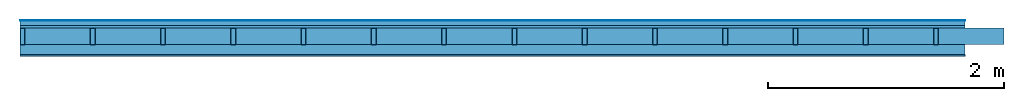
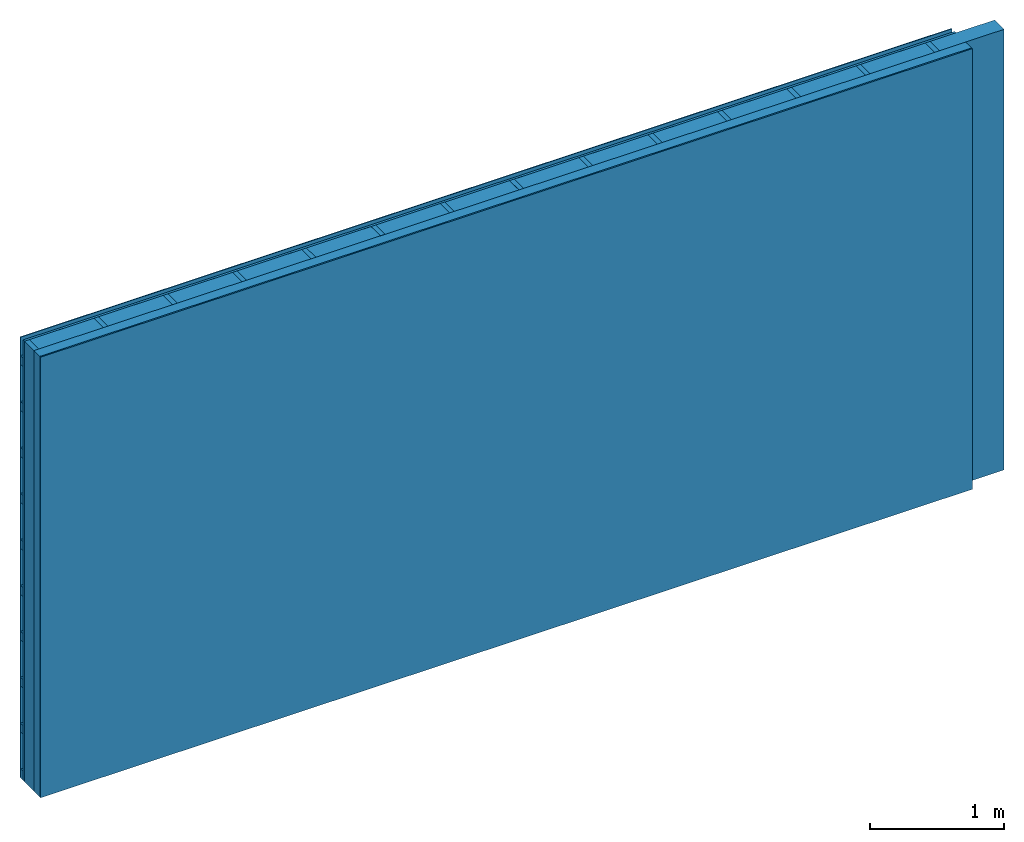
# One storey: 4 plates, 3 members, 1 element without a shape of its own.
"""IFC4 building model written with IfcOpenShell, lengths in metres."""

from ifc_helpers import new_model, si_unit, derived_unit, direction, frame, frame_2d, origin, origin_with_axes, place, context, project, spatial, rectangle, extrude, material, layer, layer_set, type_object, element, aggregate, save


model = new_model("IFC4")

# Units and contexts
plan_context = context("Plan", 3, precision=1e-05, world=origin(), true_north=direction((0.0, 1.0)))
model_context = context("Model", 3, precision=1e-05, world=origin(), true_north=direction((0.0, 1.0)))
ifc_project = project(units=[si_unit("LENGTHUNIT", "METRE"), derived_unit("SOUNDPRESSUREUNIT", [(si_unit("PRESSUREUNIT", "PASCAL", prefix="MICRO"), 0)]), si_unit("ENERGYUNIT", "JOULE", prefix="MEGA"), si_unit("MASSUNIT", "GRAM", prefix="KILO"), derived_unit("THERMALTRANSMITTANCEUNIT", [(si_unit("POWERUNIT", "WATT"), 1), (si_unit("AREAUNIT", "SQUARE_METRE"), -1), (si_unit("THERMODYNAMICTEMPERATUREUNIT", "KELVIN"), -1)]), derived_unit("AREADENSITYUNIT", [(si_unit("MASSUNIT", "GRAM", prefix="KILO"), 1), (si_unit("AREAUNIT", "SQUARE_METRE"), -1)]), derived_unit("USERDEFINED", [(si_unit("ENERGYUNIT", "JOULE", prefix="MEGA"), 1), (si_unit("AREAUNIT", "SQUARE_METRE"), -1)])], contexts=[plan_context, model_context])

# Site, building, storey
site = spatial("IfcSite", under=ifc_project)
building_placement = place(None, origin())
building = spatial("IfcBuilding", under=site, at=building_placement)
storey_placement = place(building_placement, origin())
storey = spatial("IfcBuildingStorey", under=building, at=storey_placement)

# Wall, members, plates
ifc_material_1 = material(Name="mineral, cement-based building board", Category="03.003")
ifc_layer_1 = layer(ifc_material_1, 0.008, Name="Cover 1st layer")
ifc_layer_2 = layer(None, 0.04, Name="Battens / profiles (ventilation)")
ifc_material_2 = material(Category="10.009")
ifc_layer_3 = layer(ifc_material_2, 0.02, Name="outside 1st layer")
ifc_material_3 = material(Name="of the art")
ifc_layer_4 = layer(ifc_material_3, 0.0, Name="Bond")
ifc_layer_5 = layer(None, 0.14, Name="Support")
ifc_layer_6 = layer(ifc_material_3, 0.0, Name="Bond")
ifc_material_4 = material(Name="Solid timber panel")
ifc_layer_7 = layer(ifc_material_4, 0.087, Name="1st layer")
ifc_material_5 = material(Name="Plasterboard type A", Category="03.008")
ifc_layer_8 = layer(ifc_material_5, 0.0125, Name="Covering 1st layer")
ifc_material_6 = material(Name="joints", Category="04.017")
ifc_layer_9 = layer(ifc_material_6, 0.0, Name="Surface")
ifc_layer_set = layer_set([ifc_layer_1, ifc_layer_2, ifc_layer_3, ifc_layer_4, ifc_layer_5, ifc_layer_6, ifc_layer_7, ifc_layer_8, ifc_layer_9])
wall_type = type_object("IfcWallType", Name="D0969", PredefinedType="NOTDEFINED", material=ifc_layer_set)
wall_placement = place(None, frame((0.0, 0.0, 0.0), z_axis=(0.0, -1.0, 0.0), x_axis=(1.0, 0.0, 0.0)))
wall = element("IfcWall", 1, at=wall_placement, inside=storey, type_object=wall_type, material=ifc_layer_set, Name="Wall #1")
ifc_material_7 = material()
member_1_placement = place(wall_placement, origin())
member_1 = element("IfcMember", 2, at=member_1_placement, material=ifc_material_7, Name="Battens / profiles (ventilation)", context=plan_context, shape_type="SweptSolid", body=[
    extrude(rectangle(XDim=0.08, YDim=0.04, at=frame_2d((0.04, 0.02), x_axis=(1.0, 0.0))), frame((0.0, 0.0, 0.008), z_axis=(1.0, 0.0, 0.0), x_axis=(0.0, 1.0, 0.0)), (0.0, 0.0, 1.0), 8.0),
    extrude(rectangle(XDim=0.08, YDim=0.04, at=frame_2d((0.04, 0.02), x_axis=(1.0, 0.0))), frame((0.0, 0.417, 0.008), z_axis=(1.0, 0.0, 0.0), x_axis=(0.0, 1.0, 0.0)), (0.0, 0.0, 1.0), 8.0),
    extrude(rectangle(XDim=0.08, YDim=0.04, at=frame_2d((0.04, 0.02), x_axis=(1.0, 0.0))), frame((0.0, 0.834, 0.008), z_axis=(1.0, 0.0, 0.0), x_axis=(0.0, 1.0, 0.0)), (0.0, 0.0, 1.0), 8.0),
    extrude(rectangle(XDim=0.08, YDim=0.04, at=frame_2d((0.04, 0.02), x_axis=(1.0, 0.0))), frame((0.0, 1.251, 0.008), z_axis=(1.0, 0.0, 0.0), x_axis=(0.0, 1.0, 0.0)), (0.0, 0.0, 1.0), 8.0),
    extrude(rectangle(XDim=0.08, YDim=0.04, at=frame_2d((0.04, 0.02), x_axis=(1.0, 0.0))), frame((0.0, 1.668, 0.008), z_axis=(1.0, 0.0, 0.0), x_axis=(0.0, 1.0, 0.0)), (0.0, 0.0, 1.0), 8.0),
    extrude(rectangle(XDim=0.08, YDim=0.04, at=frame_2d((0.04, 0.02), x_axis=(1.0, 0.0))), frame((0.0, 2.085, 0.008), z_axis=(1.0, 0.0, 0.0), x_axis=(0.0, 1.0, 0.0)), (0.0, 0.0, 1.0), 8.0),
    extrude(rectangle(XDim=0.08, YDim=0.04, at=frame_2d((0.04, 0.02), x_axis=(1.0, 0.0))), frame((0.0, 2.502, 0.008), z_axis=(1.0, 0.0, 0.0), x_axis=(0.0, 1.0, 0.0)), (0.0, 0.0, 1.0), 8.0),
    extrude(rectangle(XDim=0.08, YDim=0.04, at=frame_2d((0.04, 0.02), x_axis=(1.0, 0.0))), frame((0.0, 2.919, 0.008), z_axis=(1.0, 0.0, 0.0), x_axis=(0.0, 1.0, 0.0)), (0.0, 0.0, 1.0), 8.0),
    extrude(rectangle(XDim=0.08, YDim=0.04, at=frame_2d((0.04, 0.02), x_axis=(1.0, 0.0))), frame((0.0, 3.336, 0.008), z_axis=(1.0, 0.0, 0.0), x_axis=(0.0, 1.0, 0.0)), (0.0, 0.0, 1.0), 8.0),
    extrude(rectangle(XDim=0.08, YDim=0.04, at=frame_2d((0.04, 0.02), x_axis=(1.0, 0.0))), frame((0.0, 3.753, 0.008), z_axis=(1.0, 0.0, 0.0), x_axis=(0.0, 1.0, 0.0)), (0.0, 0.0, 1.0), 8.0),
])
ifc_material_8 = material()
member_2_placement = place(wall_placement, origin())
member_2 = element("IfcMember", 3, at=member_2_placement, material=ifc_material_8, Name="Support", context=plan_context, shape_type="SweptSolid", body=[
    extrude(rectangle(XDim=0.04, YDim=0.14, at=frame_2d((0.02, 0.07), x_axis=(1.0, 0.0))), frame((0.0, 4.0, 0.068), z_axis=(0.0, -1.0, 0.0), x_axis=(1.0, 0.0, 0.0)), (0.0, 0.0, 1.0), 4.0),
    extrude(rectangle(XDim=0.04, YDim=0.14, at=frame_2d((0.02, 0.07), x_axis=(1.0, 0.0))), frame((0.595, 4.0, 0.068), z_axis=(0.0, -1.0, 0.0), x_axis=(1.0, 0.0, 0.0)), (0.0, 0.0, 1.0), 4.0),
    extrude(rectangle(XDim=0.04, YDim=0.14, at=frame_2d((0.02, 0.07), x_axis=(1.0, 0.0))), frame((1.19, 4.0, 0.068), z_axis=(0.0, -1.0, 0.0), x_axis=(1.0, 0.0, 0.0)), (0.0, 0.0, 1.0), 4.0),
    extrude(rectangle(XDim=0.04, YDim=0.14, at=frame_2d((0.02, 0.07), x_axis=(1.0, 0.0))), frame((1.785, 4.0, 0.068), z_axis=(0.0, -1.0, 0.0), x_axis=(1.0, 0.0, 0.0)), (0.0, 0.0, 1.0), 4.0),
    extrude(rectangle(XDim=0.04, YDim=0.14, at=frame_2d((0.02, 0.07), x_axis=(1.0, 0.0))), frame((2.38, 4.0, 0.068), z_axis=(0.0, -1.0, 0.0), x_axis=(1.0, 0.0, 0.0)), (0.0, 0.0, 1.0), 4.0),
    extrude(rectangle(XDim=0.04, YDim=0.14, at=frame_2d((0.02, 0.07), x_axis=(1.0, 0.0))), frame((2.975, 4.0, 0.068), z_axis=(0.0, -1.0, 0.0), x_axis=(1.0, 0.0, 0.0)), (0.0, 0.0, 1.0), 4.0),
    extrude(rectangle(XDim=0.04, YDim=0.14, at=frame_2d((0.02, 0.07), x_axis=(1.0, 0.0))), frame((3.57, 4.0, 0.068), z_axis=(0.0, -1.0, 0.0), x_axis=(1.0, 0.0, 0.0)), (0.0, 0.0, 1.0), 4.0),
    extrude(rectangle(XDim=0.04, YDim=0.14, at=frame_2d((0.02, 0.07), x_axis=(1.0, 0.0))), frame((4.165, 4.0, 0.068), z_axis=(0.0, -1.0, 0.0), x_axis=(1.0, 0.0, 0.0)), (0.0, 0.0, 1.0), 4.0),
    extrude(rectangle(XDim=0.04, YDim=0.14, at=frame_2d((0.02, 0.07), x_axis=(1.0, 0.0))), frame((4.76, 4.0, 0.068), z_axis=(0.0, -1.0, 0.0), x_axis=(1.0, 0.0, 0.0)), (0.0, 0.0, 1.0), 4.0),
    extrude(rectangle(XDim=0.04, YDim=0.14, at=frame_2d((0.02, 0.07), x_axis=(1.0, 0.0))), frame((5.355, 4.0, 0.068), z_axis=(0.0, -1.0, 0.0), x_axis=(1.0, 0.0, 0.0)), (0.0, 0.0, 1.0), 4.0),
    extrude(rectangle(XDim=0.04, YDim=0.14, at=frame_2d((0.02, 0.07), x_axis=(1.0, 0.0))), frame((5.95, 4.0, 0.068), z_axis=(0.0, -1.0, 0.0), x_axis=(1.0, 0.0, 0.0)), (0.0, 0.0, 1.0), 4.0),
    extrude(rectangle(XDim=0.04, YDim=0.14, at=frame_2d((0.02, 0.07), x_axis=(1.0, 0.0))), frame((6.545, 4.0, 0.068), z_axis=(0.0, -1.0, 0.0), x_axis=(1.0, 0.0, 0.0)), (0.0, 0.0, 1.0), 4.0),
    extrude(rectangle(XDim=0.04, YDim=0.14, at=frame_2d((0.02, 0.07), x_axis=(1.0, 0.0))), frame((7.14, 4.0, 0.068), z_axis=(0.0, -1.0, 0.0), x_axis=(1.0, 0.0, 0.0)), (0.0, 0.0, 1.0), 4.0),
    extrude(rectangle(XDim=0.04, YDim=0.14, at=frame_2d((0.02, 0.07), x_axis=(1.0, 0.0))), frame((7.735, 4.0, 0.068), z_axis=(0.0, -1.0, 0.0), x_axis=(1.0, 0.0, 0.0)), (0.0, 0.0, 1.0), 4.0),
])
ifc_material_9 = material()
member_3_placement = place(wall_placement, origin())
member_3 = element("IfcMember", 4, at=member_3_placement, material=ifc_material_9, Name="Cavity", context=plan_context, shape_type="SweptSolid", body=[
    extrude(rectangle(XDim=0.555, YDim=0.14, at=frame_2d((0.2775, 0.07), x_axis=(1.0, 0.0))), frame((0.04, 4.0, 0.068), z_axis=(0.0, -1.0, 0.0), x_axis=(1.0, 0.0, 0.0)), (0.0, 0.0, 1.0), 4.0),
    extrude(rectangle(XDim=0.555, YDim=0.14, at=frame_2d((0.2775, 0.07), x_axis=(1.0, 0.0))), frame((0.635, 4.0, 0.068), z_axis=(0.0, -1.0, 0.0), x_axis=(1.0, 0.0, 0.0)), (0.0, 0.0, 1.0), 4.0),
    extrude(rectangle(XDim=0.555, YDim=0.14, at=frame_2d((0.2775, 0.07), x_axis=(1.0, 0.0))), frame((1.23, 4.0, 0.068), z_axis=(0.0, -1.0, 0.0), x_axis=(1.0, 0.0, 0.0)), (0.0, 0.0, 1.0), 4.0),
    extrude(rectangle(XDim=0.555, YDim=0.14, at=frame_2d((0.2775, 0.07), x_axis=(1.0, 0.0))), frame((1.825, 4.0, 0.068), z_axis=(0.0, -1.0, 0.0), x_axis=(1.0, 0.0, 0.0)), (0.0, 0.0, 1.0), 4.0),
    extrude(rectangle(XDim=0.555, YDim=0.14, at=frame_2d((0.2775, 0.07), x_axis=(1.0, 0.0))), frame((2.42, 4.0, 0.068), z_axis=(0.0, -1.0, 0.0), x_axis=(1.0, 0.0, 0.0)), (0.0, 0.0, 1.0), 4.0),
    extrude(rectangle(XDim=0.555, YDim=0.14, at=frame_2d((0.2775, 0.07), x_axis=(1.0, 0.0))), frame((3.015, 4.0, 0.068), z_axis=(0.0, -1.0, 0.0), x_axis=(1.0, 0.0, 0.0)), (0.0, 0.0, 1.0), 4.0),
    extrude(rectangle(XDim=0.555, YDim=0.14, at=frame_2d((0.2775, 0.07), x_axis=(1.0, 0.0))), frame((3.61, 4.0, 0.068), z_axis=(0.0, -1.0, 0.0), x_axis=(1.0, 0.0, 0.0)), (0.0, 0.0, 1.0), 4.0),
    extrude(rectangle(XDim=0.555, YDim=0.14, at=frame_2d((0.2775, 0.07), x_axis=(1.0, 0.0))), frame((4.205, 4.0, 0.068), z_axis=(0.0, -1.0, 0.0), x_axis=(1.0, 0.0, 0.0)), (0.0, 0.0, 1.0), 4.0),
    extrude(rectangle(XDim=0.555, YDim=0.14, at=frame_2d((0.2775, 0.07), x_axis=(1.0, 0.0))), frame((4.8, 4.0, 0.068), z_axis=(0.0, -1.0, 0.0), x_axis=(1.0, 0.0, 0.0)), (0.0, 0.0, 1.0), 4.0),
    extrude(rectangle(XDim=0.555, YDim=0.14, at=frame_2d((0.2775, 0.07), x_axis=(1.0, 0.0))), frame((5.395, 4.0, 0.068), z_axis=(0.0, -1.0, 0.0), x_axis=(1.0, 0.0, 0.0)), (0.0, 0.0, 1.0), 4.0),
    extrude(rectangle(XDim=0.555, YDim=0.14, at=frame_2d((0.2775, 0.07), x_axis=(1.0, 0.0))), frame((5.99, 4.0, 0.068), z_axis=(0.0, -1.0, 0.0), x_axis=(1.0, 0.0, 0.0)), (0.0, 0.0, 1.0), 4.0),
    extrude(rectangle(XDim=0.555, YDim=0.14, at=frame_2d((0.2775, 0.07), x_axis=(1.0, 0.0))), frame((6.585, 4.0, 0.068), z_axis=(0.0, -1.0, 0.0), x_axis=(1.0, 0.0, 0.0)), (0.0, 0.0, 1.0), 4.0),
    extrude(rectangle(XDim=0.555, YDim=0.14, at=frame_2d((0.2775, 0.07), x_axis=(1.0, 0.0))), frame((7.18, 4.0, 0.068), z_axis=(0.0, -1.0, 0.0), x_axis=(1.0, 0.0, 0.0)), (0.0, 0.0, 1.0), 4.0),
    extrude(rectangle(XDim=0.555, YDim=0.14, at=frame_2d((0.2775, 0.07), x_axis=(1.0, 0.0))), frame((7.775, 4.0, 0.068), z_axis=(0.0, -1.0, 0.0), x_axis=(1.0, 0.0, 0.0)), (0.0, 0.0, 1.0), 4.0),
])
plate_1_placement = place(wall_placement, origin())
plate_1 = element("IfcPlate", 5, at=plate_1_placement, material=ifc_material_1, Name="Cover 1st layer", context=plan_context, shape_type="SweptSolid", body=[
    extrude(rectangle(XDim=8.0, YDim=4.0, at=frame_2d((4.0, 2.0), x_axis=(1.0, 0.0))), origin_with_axes(), (0.0, 0.0, 1.0), 0.008),
])
plate_2_placement = place(wall_placement, origin())
plate_2 = element("IfcPlate", 6, at=plate_2_placement, material=ifc_material_2, Name="outside 1st layer", context=plan_context, shape_type="SweptSolid", body=[
    extrude(rectangle(XDim=8.0, YDim=4.0, at=frame_2d((4.0, 2.0), x_axis=(1.0, 0.0))), frame((0.0, 0.0, 0.048), z_axis=(0.0, 0.0, 1.0), x_axis=(1.0, 0.0, 0.0)), (0.0, 0.0, 1.0), 0.02),
])
plate_3_placement = place(wall_placement, origin())
plate_3 = element("IfcPlate", 7, at=plate_3_placement, material=ifc_material_4, Name="1st layer", context=plan_context, shape_type="SweptSolid", body=[
    extrude(rectangle(XDim=8.0, YDim=4.0, at=frame_2d((4.0, 2.0), x_axis=(1.0, 0.0))), frame((0.0, 0.0, 0.208), z_axis=(0.0, 0.0, 1.0), x_axis=(1.0, 0.0, 0.0)), (0.0, 0.0, 1.0), 0.087),
])
plate_4_placement = place(wall_placement, origin())
plate_4 = element("IfcPlate", 8, at=plate_4_placement, material=ifc_material_5, Name="Covering 1st layer", context=plan_context, shape_type="SweptSolid", body=[
    extrude(rectangle(XDim=8.0, YDim=4.0, at=frame_2d((4.0, 2.0), x_axis=(1.0, 0.0))), frame((0.0, 0.0, 0.295), z_axis=(0.0, 0.0, 1.0), x_axis=(1.0, 0.0, 0.0)), (0.0, 0.0, 1.0), 0.0125),
])
aggregate(wall, [plate_1, member_1, plate_2, member_2, member_3, plate_3, plate_4])

save(model, "model.ifc")
